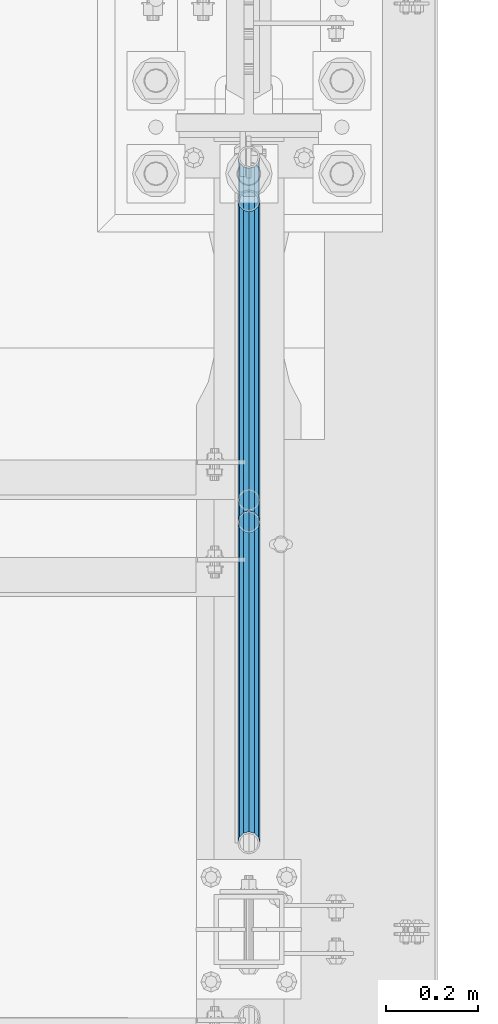
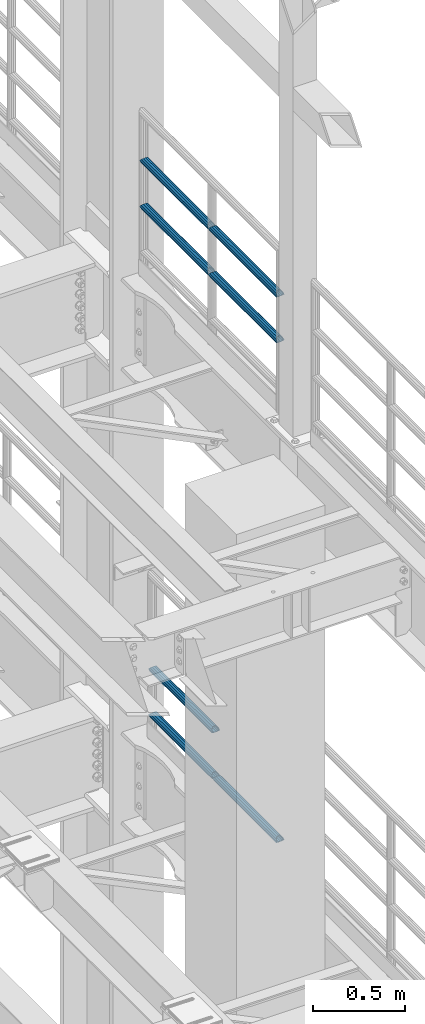
# One storey, part 1336 of 1876: 7 beams, 2 elements without a shape of their own.
"""IFC2X3 building model written with IfcOpenShell, lengths in millimetres."""

import ifcopenshell
import ifcopenshell.guid

model = None  # the IFC model being written
_history = None  # IfcOwnerHistory: only IFC2X3 demands one
_inside = {}  # id of a spatial element -> (the spatial element, [elements in it])
_under = {}  # id of a project, library or spatial element -> (it, [spatial elements below it])
_declared = {}  # id of a project -> (the project, [libraries it declares])
_typed = {}  # id of a type object -> (the type object, [elements of that type])
_made_of = {}  # id of a material, layer set ... -> (it, [elements and type objects made of it])


def new_model(schema):
    """Start an empty IFC model of exactly this schema.

    Asked for "IFC4X3", IfcOpenShell would pick the latest addendum, in which some entities
    have other attributes; the version numbers below select the first issue.
    IFC2X3 requires an IfcOwnerHistory on every rooted entity: one is made here for all.
    """
    global model, _history
    if schema == "IFC4X3":
        model = ifcopenshell.file(schema_version=(4, 3, 0, 0))
    else:
        model = ifcopenshell.file(schema=schema)
    _inside.clear()
    _under.clear()
    _declared.clear()
    _typed.clear()
    _made_of.clear()
    _history = None
    if model.schema == "IFC2X3":
        org = make("IfcOrganization", Name="unknown")
        user = make(
            "IfcPersonAndOrganization",
            ThePerson=make("IfcPerson", FamilyName="unknown"),
            TheOrganization=org,
        )
        app = make(
            "IfcApplication",
            ApplicationDeveloper=org,
            Version="unknown",
            ApplicationFullName="unknown",
            ApplicationIdentifier="unknown",
        )
        _history = make(
            "IfcOwnerHistory",
            OwningUser=user,
            OwningApplication=app,
            ChangeAction="ADDED",
            CreationDate=0,
        )
    return model


def make(cls, **values):
    """One entity of the class cls with the attributes given. An attribute that is None is left unset."""
    return model.create_entity(
        cls, **{name: value for name, value in values.items() if value is not None}
    )


def rooted(cls, **values):
    """An entity with a GlobalId (a new one), such as an element, a storey or a relation."""
    return make(cls, GlobalId=ifcopenshell.guid.new(), OwnerHistory=_history, **values)


def si_unit(unit_type, name, prefix=None):
    """IfcSIUnit, for example si_unit("LENGTHUNIT", "METRE", prefix="MILLI")."""
    return make("IfcSIUnit", UnitType=unit_type, Prefix=prefix, Name=name)


def assignment(units):
    """IfcUnitAssignment: the units of a project."""
    return None if units is None else make("IfcUnitAssignment", Units=units)


def point(xyz):
    """IfcCartesianPoint."""
    return None if xyz is None else make("IfcCartesianPoint", Coordinates=xyz)


def direction(xyz):
    """IfcDirection."""
    return None if xyz is None else make("IfcDirection", DirectionRatios=xyz)


def frame(location, z_axis=None, x_axis=None):
    """IfcAxis2Placement3D, a coordinate frame: its origin and axes. An axis left out is left unset."""
    return make(
        "IfcAxis2Placement3D",
        Location=point(location),
        Axis=direction(z_axis),
        RefDirection=direction(x_axis),
    )


def origin_with_axes():
    """The frame at (0, 0, 0) with the z axis (0, 0, 1) and the x axis (1, 0, 0) written out."""
    return frame((0.0, 0.0, 0.0), z_axis=(0.0, 0.0, 1.0), x_axis=(1.0, 0.0, 0.0))


def place(relative_to, where):
    """IfcLocalPlacement: puts the frame where relative to a parent placement (None: the world)."""
    return make(
        "IfcLocalPlacement", PlacementRelTo=relative_to, RelativePlacement=where
    )


def context(
    kind, dimensions, precision=None, world=None, true_north=None, identifier=None
):
    """IfcGeometricRepresentationContext, for example the 3D "Model" context."""
    return make(
        "IfcGeometricRepresentationContext",
        ContextIdentifier=identifier,
        ContextType=kind,
        CoordinateSpaceDimension=dimensions,
        Precision=precision,
        WorldCoordinateSystem=world,
        TrueNorth=true_north,
    )


def subcontext(parent, identifier, kind, view, scale=None):
    """IfcGeometricRepresentationSubContext, for example "Body" below "Model"."""
    return make(
        "IfcGeometricRepresentationSubContext",
        ContextIdentifier=identifier,
        ContextType=kind,
        ParentContext=parent,
        TargetScale=scale,
        TargetView=view,
    )


def project(units=None, contexts=None):
    """IfcProject with its units and contexts."""
    return rooted(
        "IfcProject",
        Name="project",
        RepresentationContexts=contexts,
        UnitsInContext=assignment(units),
    )


def spatial(cls, under=None, at=None, **own):
    """A site, building, storey or space (cls), placed at a placement, below another one or the project."""
    s = rooted(cls, ObjectPlacement=at, **own)
    if under is not None:
        _under.setdefault(under.id(), (under, []))[1].append(s)
    return s


def faces_of(points, faces, orient=None, outer=None):
    """IfcFace entities. A face is a list of loops; a loop is a list of indices into points, from 0.

    orient and outer hold one flag for each loop. By default every Orientation is true, the
    first loop of a face is its IfcFaceOuterBound and the others are IfcFaceBound.
    """
    made = []
    for i, loops in enumerate(faces):
        bounds = []
        for j, loop in enumerate(loops):
            is_outer = j == 0 if outer is None else outer[i][j]
            bounds.append(
                make(
                    "IfcFaceOuterBound" if is_outer else "IfcFaceBound",
                    Bound=make("IfcPolyLoop", Polygon=[points[k] for k in loop]),
                    Orientation=True if orient is None else orient[i][j],
                )
            )
        made.append(make("IfcFace", Bounds=bounds))
    return made


def faceted_brep(points, faces, orient=None, outer=None, voids=None):
    """IfcFacetedBrep: a solid bounded by flat faces; with voids (closed shells), ...WithVoids."""
    shared = [point(p) for p in points]
    hull = make("IfcClosedShell", CfsFaces=faces_of(shared, faces, orient, outer))
    if voids is None:
        return make("IfcFacetedBrep", Outer=hull)
    return make(
        "IfcFacetedBrepWithVoids",
        Outer=hull,
        Voids=[
            make(cls, CfsFaces=faces_of(shared, fs, o, b)) for cls, fs, o, b in voids
        ],
    )


def shape(context_of_items, identifier, shape_type, items):
    """IfcShapeRepresentation: the items that make up one representation, for example the "Body"."""
    return make(
        "IfcShapeRepresentation",
        ContextOfItems=context_of_items,
        RepresentationIdentifier=identifier,
        RepresentationType=shape_type,
        Items=items,
    )


def material(Name=None, Category=None):
    """IfcMaterial."""
    return make("IfcMaterial", Name=Name, Category=Category)


def made_of(thing, what):
    """Note that an element or type object is made of a material, layer set ...; save() writes the relation."""
    if what is not None:
        _made_of.setdefault(what.id(), (what, []))[1].append(thing)
    return thing


def type_object(cls, material=None, **own):
    """A type object (cls), such as IfcWallType, which elements share."""
    return made_of(rooted(cls, **own), material)


def element(
    cls,
    number,
    at=None,
    inside=None,
    cuts=None,
    type_object=None,
    material=None,
    context=None,
    identifier="Body",
    shape_type=None,
    held_by="IfcProductDefinitionShape",
    body=None,
    shapes=None,
    **own,
):
    """One element of the class cls, such as IfcWall. Its Tag is "e" and its number.

    at: its placement. inside: the storey or other place that contains it. cuts: it is an
    opening in that element (IfcRelVoidsElement). A single representation is given by context,
    identifier, shape_type and body (its items); several are given by shapes. held_by: the class
    of the entity that holds the representations. save() writes the other relations.
    """
    e = rooted(cls, Tag="e%d" % number, ObjectPlacement=at, **own)
    if body is not None:
        shapes = [shape(context, identifier, shape_type, body)]
    if shapes is not None:
        e.Representation = make(held_by, Representations=shapes)
    if inside is not None:
        _inside.setdefault(inside.id(), (inside, []))[1].append(e)
    if cuts is not None:
        rooted(
            "IfcRelVoidsElement", RelatingBuildingElement=cuts, RelatedOpeningElement=e
        )
    if type_object is not None:
        _typed.setdefault(type_object.id(), (type_object, []))[1].append(e)
    return made_of(e, material)


def aggregate(whole, parts):
    """IfcRelAggregates: a whole, such as a stair, and the parts it consists of."""
    return rooted("IfcRelAggregates", RelatingObject=whole, RelatedObjects=parts)


def save(model, path):
    """Write the relations noted so far, then the file.

    IfcRelAggregates (storeys below a building ...), IfcRelContainedInSpatialStructure (elements
    in a storey), IfcRelDefinesByType, IfcRelAssociatesMaterial and IfcRelDeclares: one each for
    every whole, place, type object, material and project.
    """
    for whole, parts in _under.values():
        aggregate(whole, parts)
    for where, things in _inside.values():
        rooted(
            "IfcRelContainedInSpatialStructure",
            RelatedElements=things,
            RelatingStructure=where,
        )
    for kind, things in _typed.values():
        rooted("IfcRelDefinesByType", RelatedObjects=things, RelatingType=kind)
    for what, things in _made_of.values():
        rooted("IfcRelAssociatesMaterial", RelatedObjects=things, RelatingMaterial=what)
    for by, libraries in _declared.values():
        rooted("IfcRelDeclares", RelatingContext=by, RelatedDefinitions=libraries)
    model.write(path)


model = new_model("IFC2X3")

# Units and contexts
model_context = context("Model", 3, precision=1e-05, world=origin_with_axes())
body_context = subcontext(model_context, "Body", "Model", "MODEL_VIEW")
ifc_project = project(units=[si_unit("LENGTHUNIT", "METRE", prefix="MILLI"), si_unit("AREAUNIT", "SQUARE_METRE"), si_unit("VOLUMEUNIT", "CUBIC_METRE"), si_unit("MASSUNIT", "GRAM", prefix="KILO"), si_unit("TIMEUNIT", "SECOND"), si_unit("PLANEANGLEUNIT", "RADIAN"), si_unit("SOLIDANGLEUNIT", "STERADIAN"), si_unit("THERMODYNAMICTEMPERATUREUNIT", "DEGREE_CELSIUS"), si_unit("LUMINOUSINTENSITYUNIT", "LUMEN")], contexts=[model_context])

# Site, building, storey
site_placement = place(None, origin_with_axes())
site = spatial("IfcSite", under=ifc_project, at=site_placement, CompositionType="ELEMENT")
building_placement = place(site_placement, origin_with_axes())
building = spatial("IfcBuilding", under=site, at=building_placement, Name="Undefined", CompositionType="ELEMENT")
storey_placement = place(building_placement, origin_with_axes())
storey = spatial("IfcBuildingStorey", under=building, at=storey_placement, Name="Undefined", CompositionType="ELEMENT", Elevation=0.0)

# Assembly, beams
assembly_1_placement = place(storey_placement, origin_with_axes())
assembly_1 = element("IfcElementAssembly", 1, at=assembly_1_placement, inside=storey, Name="RAIL", AssemblyPlace="NOTDEFINED", PredefinedType="RIGID_FRAME")
ifc_material = material()
beam_type = type_object("IfcBeamType", Name="PIPE1-1/2SCH40", PredefinedType="NOTDEFINED")
beam_1_placement = place(assembly_1_placement, frame((7620.0, 5777.23, 8620.125), z_axis=(0.0, 0.0, -1.0), x_axis=(0.0, 1.0, 0.0)))
beam_1 = element("IfcBeam", 2, at=beam_1_placement, type_object=beam_type, material=ifc_material, Name="RAIL", ObjectType="PIPE1-1/2SCH40", context=body_context, shape_type="Brep", body=[
    faceted_brep([(0.0, 24.1299999999992, 0.0), (12.0650000000064, 20.8971929933177, -12.0649999999987), (12.0650000000064, 20.8971929933177, 12.0649999999987), (12.0650000000064, -20.8971929933177, 12.0649999999987), (12.0650000000064, -20.8971929933177, -12.0649999999987), (0.0, -24.1299999999992, 0.0), (20.8971929933249, -12.0650000000005, 20.8971929933177), (20.8971929933249, -12.0650000000005, 15.8661214311796), (15.2545715621445, -17.7076214311801, 10.2235000000001), (12.5151929933249, -20.4470000000001, 0.0), (15.2545715621445, -17.7076214311801, -10.2235000000001), (20.8971929933249, -12.0650000000005, -15.8661214311796), (20.8971929933249, -12.0650000000005, -20.8971929933177), (24.1300000000063, 0.0, -20.4470000000001), (24.1300000000063, 0.0, -24.130000000001), (21.3906214311868, -10.2235000000001, -17.7076214311819), (21.3906214311868, 10.2235000000001, -17.7076214311819), (20.8971929933249, 12.0650000000005, -15.8661214311796), (20.8971929933249, 12.0650000000005, -20.8971929933177), (15.2545715621445, 17.7076214311801, -10.2235000000001), (12.5151929933249, 20.4470000000001, 0.0), (15.2545715621445, 17.7076214311801, 10.2235000000001), (20.8971929933249, 12.0650000000005, 15.8661214311796), (20.8971929933249, 12.0650000000005, 20.8971929933177), (21.3906214311868, 10.2235000000001, 17.7076214311819), (24.1300000000064, 0.0, 20.4470000000001), (24.1300000000064, 0.0, 24.130000000001), (21.3906214311868, -10.2235000000001, 17.7076214311819), (748.982500000002, 24.1300000000001, 0.0), (736.917500000002, 20.8971929933186, -12.0649999999987), (728.085307006683, 12.0649999999996, -20.8971929933177), (748.982500000002, -24.1300000000001, 0.0), (736.917500000002, -20.8971929933186, -12.0649999999987), (736.917500000002, -20.8971929933186, 12.0649999999987), (728.085307006683, -12.0649999999996, 20.8971929933177), (728.085307006683, -12.0649999999996, -20.8971929933177), (724.852500000002, 0.0, -24.130000000001), (727.591878568821, 10.2235000000001, -17.7076214311819), (724.852500000002, 0.0, -20.4470000000001), (728.085307006683, 12.0649999999996, -15.8661214311796), (728.085307006683, -12.0649999999996, -15.8661214311796), (727.591878568821, -10.2235000000001, -17.7076214311819), (733.727928437864, -17.7076214311801, -10.2235000000001), (736.467307006683, -20.4470000000001, 0.0), (733.727928437864, -17.7076214311801, 10.2235000000001), (728.085307006683, -12.0649999999996, 15.8661214311796), (727.591878568821, -10.2235000000001, 17.7076214311819), (724.852500000002, 0.0, 20.4470000000001), (724.852500000002, 0.0, 24.130000000001), (728.085307006683, 12.0649999999996, 20.8971929933177), (736.917500000002, 20.8971929933186, 12.0649999999987), (728.085307006683, 12.0649999999996, 15.8661214311796), (733.727928437864, 17.7076214311801, 10.2235000000001), (736.467307006683, 20.4470000000001, 0.0), (733.727928437864, 17.7076214311801, -10.2235000000001), (727.591878568821, 10.2235000000001, 17.7076214311819)], [[[0, 1, 2]], [[3, 4, 5]], [[6, 7, 8, 9, 10, 11, 12, 4, 3]], [[13, 14, 12, 11, 15]], [[16, 17, 18, 14, 13]], [[2, 1, 18, 17, 19, 20, 21, 22, 23]], [[23, 22, 24, 25, 26]], [[26, 25, 27, 7, 6]], [[1, 0, 28, 29]], [[18, 1, 29, 30]], [[31, 32, 33]], [[6, 3, 33, 34]], [[3, 5, 31, 33]], [[5, 4, 32, 31]], [[4, 12, 35, 32]], [[12, 14, 36, 35]], [[14, 18, 30, 36]], [[37, 38, 36, 30, 39]], [[40, 35, 36, 38, 41]], [[33, 32, 35, 40, 42, 43, 44, 45, 34]], [[34, 45, 46, 47, 48]], [[26, 6, 34, 48]], [[2, 23, 49, 50]], [[23, 26, 48, 49]], [[0, 2, 50, 28]], [[28, 50, 29]], [[49, 51, 52, 53, 54, 39, 30, 29, 50]], [[48, 47, 55, 51, 49]], [[25, 24, 55, 47]], [[55, 24, 22, 21, 52, 51]], [[21, 20, 53, 52]], [[20, 19, 54, 53]], [[19, 17, 16, 37, 39, 54]], [[16, 13, 38, 37]], [[13, 15, 41, 38]], [[41, 15, 11, 10, 42, 40]], [[10, 9, 43, 42]], [[9, 8, 44, 43]], [[8, 7, 27, 46, 45, 44]], [[27, 25, 47, 46]]]),
])
beam_2_placement = place(assembly_1_placement, frame((7620.0, 6526.2125, 8620.125), z_axis=(0.0, 0.0, -1.0), x_axis=(0.0, 1.0, 0.0)))
beam_2 = element("IfcBeam", 3, at=beam_2_placement, type_object=beam_type, material=ifc_material, Name="RAIL", ObjectType="PIPE1-1/2SCH40", context=body_context, shape_type="Brep", body=[
    faceted_brep([(0.0, 24.1299999999992, 0.0), (12.0650000000064, 20.8971929933177, -12.0649999999987), (12.0650000000064, 20.8971929933177, 12.0649999999987), (12.0650000000064, -20.8971929933177, 12.0649999999987), (12.0650000000064, -20.8971929933177, -12.0649999999987), (0.0, -24.1299999999992, 0.0), (20.8971929933249, -12.0650000000005, 20.8971929933177), (20.8971929933249, -12.0650000000005, 15.8661214311796), (15.2545715621445, -17.7076214311801, 10.2235000000001), (12.5151929933249, -20.4470000000001, 0.0), (15.2545715621445, -17.7076214311801, -10.2235000000001), (20.8971929933249, -12.0650000000005, -15.8661214311796), (20.8971929933249, -12.0650000000005, -20.8971929933177), (24.1300000000063, 0.0, -20.4470000000001), (24.1300000000063, 0.0, -24.130000000001), (21.3906214311868, -10.2235000000001, -17.7076214311819), (21.3906214311868, 10.2235000000001, -17.7076214311819), (20.8971929933249, 12.0650000000005, -15.8661214311796), (20.8971929933249, 12.0650000000005, -20.8971929933177), (15.2545715621445, 17.7076214311801, -10.2235000000001), (12.5151929933249, 20.4470000000001, 0.0), (15.2545715621445, 17.7076214311801, 10.2235000000001), (20.8971929933249, 12.0650000000005, 15.8661214311796), (20.8971929933249, 12.0650000000005, 20.8971929933177), (21.3906214311868, 10.2235000000001, 17.7076214311819), (24.1300000000064, 0.0, 20.4470000000001), (24.1300000000064, 0.0, 24.130000000001), (21.3906214311868, -10.2235000000001, 17.7076214311819), (748.982500000002, 24.1300000000001, 0.0), (736.917500000002, 20.8971929933186, -12.0649999999987), (728.085307006683, 12.0649999999996, -20.8971929933177), (748.982500000002, -24.1300000000001, 0.0), (736.917500000002, -20.8971929933186, -12.0649999999987), (736.917500000002, -20.8971929933186, 12.0649999999987), (728.085307006683, -12.0649999999996, 20.8971929933177), (728.085307006683, -12.0649999999996, -20.8971929933177), (724.852500000002, 0.0, -24.130000000001), (727.591878568821, 10.2235000000001, -17.7076214311819), (724.852500000002, 0.0, -20.4470000000001), (728.085307006683, 12.0649999999996, -15.8661214311796), (728.085307006683, -12.0649999999996, -15.8661214311796), (727.591878568821, -10.2235000000001, -17.7076214311819), (733.727928437864, -17.7076214311801, -10.2235000000001), (736.467307006683, -20.4470000000001, 0.0), (733.727928437864, -17.7076214311801, 10.2235000000001), (728.085307006683, -12.0649999999996, 15.8661214311796), (727.591878568821, -10.2235000000001, 17.7076214311819), (724.852500000002, 0.0, 20.4470000000001), (724.852500000002, 0.0, 24.130000000001), (728.085307006683, 12.0649999999996, 20.8971929933177), (736.917500000002, 20.8971929933186, 12.0649999999987), (728.085307006683, 12.0649999999996, 15.8661214311796), (733.727928437864, 17.7076214311801, 10.2235000000001), (736.467307006683, 20.4470000000001, 0.0), (733.727928437864, 17.7076214311801, -10.2235000000001), (727.591878568821, 10.2235000000001, 17.7076214311819)], [[[0, 1, 2]], [[3, 4, 5]], [[6, 7, 8, 9, 10, 11, 12, 4, 3]], [[13, 14, 12, 11, 15]], [[16, 17, 18, 14, 13]], [[2, 1, 18, 17, 19, 20, 21, 22, 23]], [[23, 22, 24, 25, 26]], [[26, 25, 27, 7, 6]], [[1, 0, 28, 29]], [[18, 1, 29, 30]], [[31, 32, 33]], [[6, 3, 33, 34]], [[3, 5, 31, 33]], [[5, 4, 32, 31]], [[4, 12, 35, 32]], [[12, 14, 36, 35]], [[14, 18, 30, 36]], [[37, 38, 36, 30, 39]], [[40, 35, 36, 38, 41]], [[33, 32, 35, 40, 42, 43, 44, 45, 34]], [[34, 45, 46, 47, 48]], [[26, 6, 34, 48]], [[2, 23, 49, 50]], [[23, 26, 48, 49]], [[0, 2, 50, 28]], [[28, 50, 29]], [[49, 51, 52, 53, 54, 39, 30, 29, 50]], [[48, 47, 55, 51, 49]], [[25, 24, 55, 47]], [[55, 24, 22, 21, 52, 51]], [[21, 20, 53, 52]], [[20, 19, 54, 53]], [[19, 17, 16, 37, 39, 54]], [[16, 13, 38, 37]], [[13, 15, 41, 38]], [[41, 15, 11, 10, 42, 40]], [[10, 9, 43, 42]], [[9, 8, 44, 43]], [[8, 7, 27, 46, 45, 44]], [[27, 25, 47, 46]]]),
])
beam_3_placement = place(assembly_1_placement, frame((7620.0, 5777.23, 8924.925), z_axis=(0.0, 0.0, -1.0), x_axis=(0.0, 1.0, 0.0)))
beam_3 = element("IfcBeam", 4, at=beam_3_placement, type_object=beam_type, material=ifc_material, Name="RAIL", ObjectType="PIPE1-1/2SCH40", context=body_context, shape_type="Brep", body=[
    faceted_brep([(0.0, 24.1299999999992, 0.0), (12.0650000000064, 20.8971929933177, -12.0649999999987), (12.0650000000064, 20.8971929933177, 12.0649999999987), (12.0650000000064, -20.8971929933177, 12.0649999999987), (12.0650000000064, -20.8971929933177, -12.0649999999987), (0.0, -24.1299999999992, 0.0), (20.8971929933249, -12.0650000000005, 20.8971929933177), (20.8971929933249, -12.0650000000005, 15.8661214311796), (15.2545715621445, -17.7076214311801, 10.2235000000001), (12.5151929933249, -20.4470000000001, 0.0), (15.2545715621445, -17.7076214311801, -10.2235000000001), (20.8971929933249, -12.0650000000005, -15.8661214311796), (20.8971929933249, -12.0650000000005, -20.8971929933177), (24.1300000000063, 0.0, -20.4470000000001), (24.1300000000063, 0.0, -24.130000000001), (21.3906214311868, -10.2235000000001, -17.7076214311819), (21.3906214311868, 10.2235000000001, -17.7076214311819), (20.8971929933249, 12.0650000000005, -15.8661214311796), (20.8971929933249, 12.0650000000005, -20.8971929933177), (15.2545715621445, 17.7076214311801, -10.2235000000001), (12.5151929933249, 20.4470000000001, 0.0), (15.2545715621445, 17.7076214311801, 10.2235000000001), (20.8971929933249, 12.0650000000005, 15.8661214311796), (20.8971929933249, 12.0650000000005, 20.8971929933177), (21.3906214311868, 10.2235000000001, 17.7076214311819), (24.1300000000064, 0.0, 20.4470000000001), (24.1300000000064, 0.0, 24.130000000001), (21.3906214311868, -10.2235000000001, 17.7076214311819), (748.982500000002, 24.1300000000001, 0.0), (736.917500000002, 20.8971929933186, -12.0649999999987), (728.085307006683, 12.0649999999996, -20.8971929933177), (748.982500000002, -24.1300000000001, 0.0), (736.917500000002, -20.8971929933186, -12.0649999999987), (736.917500000002, -20.8971929933186, 12.0649999999987), (728.085307006683, -12.0649999999996, 20.8971929933177), (728.085307006683, -12.0649999999996, -20.8971929933177), (724.852500000002, 0.0, -24.130000000001), (727.591878568821, 10.2235000000001, -17.7076214311819), (724.852500000002, 0.0, -20.4470000000001), (728.085307006683, 12.0649999999996, -15.8661214311796), (728.085307006683, -12.0649999999996, -15.8661214311796), (727.591878568821, -10.2235000000001, -17.7076214311819), (733.727928437864, -17.7076214311801, -10.2235000000001), (736.467307006683, -20.4470000000001, 0.0), (733.727928437864, -17.7076214311801, 10.2235000000001), (728.085307006683, -12.0649999999996, 15.8661214311796), (727.591878568821, -10.2235000000001, 17.7076214311819), (724.852500000002, 0.0, 20.4470000000001), (724.852500000002, 0.0, 24.130000000001), (728.085307006683, 12.0649999999996, 20.8971929933177), (736.917500000002, 20.8971929933186, 12.0649999999987), (728.085307006683, 12.0649999999996, 15.8661214311796), (733.727928437864, 17.7076214311801, 10.2235000000001), (736.467307006683, 20.4470000000001, 0.0), (733.727928437864, 17.7076214311801, -10.2235000000001), (727.591878568821, 10.2235000000001, 17.7076214311819)], [[[0, 1, 2]], [[3, 4, 5]], [[6, 7, 8, 9, 10, 11, 12, 4, 3]], [[13, 14, 12, 11, 15]], [[16, 17, 18, 14, 13]], [[2, 1, 18, 17, 19, 20, 21, 22, 23]], [[23, 22, 24, 25, 26]], [[26, 25, 27, 7, 6]], [[1, 0, 28, 29]], [[18, 1, 29, 30]], [[31, 32, 33]], [[6, 3, 33, 34]], [[3, 5, 31, 33]], [[5, 4, 32, 31]], [[4, 12, 35, 32]], [[12, 14, 36, 35]], [[14, 18, 30, 36]], [[37, 38, 36, 30, 39]], [[40, 35, 36, 38, 41]], [[33, 32, 35, 40, 42, 43, 44, 45, 34]], [[34, 45, 46, 47, 48]], [[26, 6, 34, 48]], [[2, 23, 49, 50]], [[23, 26, 48, 49]], [[0, 2, 50, 28]], [[28, 50, 29]], [[49, 51, 52, 53, 54, 39, 30, 29, 50]], [[48, 47, 55, 51, 49]], [[25, 24, 55, 47]], [[55, 24, 22, 21, 52, 51]], [[21, 20, 53, 52]], [[20, 19, 54, 53]], [[19, 17, 16, 37, 39, 54]], [[16, 13, 38, 37]], [[13, 15, 41, 38]], [[41, 15, 11, 10, 42, 40]], [[10, 9, 43, 42]], [[9, 8, 44, 43]], [[8, 7, 27, 46, 45, 44]], [[27, 25, 47, 46]]]),
])
beam_4_placement = place(assembly_1_placement, frame((7620.0, 6526.2125, 8924.925), z_axis=(0.0, 0.0, -1.0), x_axis=(0.0, 1.0, 0.0)))
beam_4 = element("IfcBeam", 5, at=beam_4_placement, type_object=beam_type, material=ifc_material, Name="RAIL", ObjectType="PIPE1-1/2SCH40", context=body_context, shape_type="Brep", body=[
    faceted_brep([(0.0, 24.1299999999992, 0.0), (12.0650000000064, 20.8971929933177, -12.0649999999987), (12.0650000000064, 20.8971929933177, 12.0649999999987), (12.0650000000064, -20.8971929933177, 12.0649999999987), (12.0650000000064, -20.8971929933177, -12.0649999999987), (0.0, -24.1299999999992, 0.0), (20.8971929933249, -12.0650000000005, 20.8971929933177), (20.8971929933249, -12.0650000000005, 15.8661214311796), (15.2545715621445, -17.7076214311801, 10.2235000000001), (12.5151929933249, -20.4470000000001, 0.0), (15.2545715621445, -17.7076214311801, -10.2235000000001), (20.8971929933249, -12.0650000000005, -15.8661214311796), (20.8971929933249, -12.0650000000005, -20.8971929933177), (24.1300000000063, 0.0, -20.4470000000001), (24.1300000000063, 0.0, -24.130000000001), (21.3906214311868, -10.2235000000001, -17.7076214311819), (21.3906214311868, 10.2235000000001, -17.7076214311819), (20.8971929933249, 12.0650000000005, -15.8661214311796), (20.8971929933249, 12.0650000000005, -20.8971929933177), (15.2545715621445, 17.7076214311801, -10.2235000000001), (12.5151929933249, 20.4470000000001, 0.0), (15.2545715621445, 17.7076214311801, 10.2235000000001), (20.8971929933249, 12.0650000000005, 15.8661214311796), (20.8971929933249, 12.0650000000005, 20.8971929933177), (21.3906214311868, 10.2235000000001, 17.7076214311819), (24.1300000000064, 0.0, 20.4470000000001), (24.1300000000064, 0.0, 24.130000000001), (21.3906214311868, -10.2235000000001, 17.7076214311819), (748.982500000002, 24.1300000000001, 0.0), (736.917500000002, 20.8971929933186, -12.0649999999987), (728.085307006683, 12.0649999999996, -20.8971929933177), (748.982500000002, -24.1300000000001, 0.0), (736.917500000002, -20.8971929933186, -12.0649999999987), (736.917500000002, -20.8971929933186, 12.0649999999987), (728.085307006683, -12.0649999999996, 20.8971929933177), (728.085307006683, -12.0649999999996, -20.8971929933177), (724.852500000002, 0.0, -24.130000000001), (727.591878568821, 10.2235000000001, -17.7076214311819), (724.852500000002, 0.0, -20.4470000000001), (728.085307006683, 12.0649999999996, -15.8661214311796), (728.085307006683, -12.0649999999996, -15.8661214311796), (727.591878568821, -10.2235000000001, -17.7076214311819), (733.727928437864, -17.7076214311801, -10.2235000000001), (736.467307006683, -20.4470000000001, 0.0), (733.727928437864, -17.7076214311801, 10.2235000000001), (728.085307006683, -12.0649999999996, 15.8661214311796), (727.591878568821, -10.2235000000001, 17.7076214311819), (724.852500000002, 0.0, 20.4470000000001), (724.852500000002, 0.0, 24.130000000001), (728.085307006683, 12.0649999999996, 20.8971929933177), (736.917500000002, 20.8971929933186, 12.0649999999987), (728.085307006683, 12.0649999999996, 15.8661214311796), (733.727928437864, 17.7076214311801, 10.2235000000001), (736.467307006683, 20.4470000000001, 0.0), (733.727928437864, 17.7076214311801, -10.2235000000001), (727.591878568821, 10.2235000000001, 17.7076214311819)], [[[0, 1, 2]], [[3, 4, 5]], [[6, 7, 8, 9, 10, 11, 12, 4, 3]], [[13, 14, 12, 11, 15]], [[16, 17, 18, 14, 13]], [[2, 1, 18, 17, 19, 20, 21, 22, 23]], [[23, 22, 24, 25, 26]], [[26, 25, 27, 7, 6]], [[1, 0, 28, 29]], [[18, 1, 29, 30]], [[31, 32, 33]], [[6, 3, 33, 34]], [[3, 5, 31, 33]], [[5, 4, 32, 31]], [[4, 12, 35, 32]], [[12, 14, 36, 35]], [[14, 18, 30, 36]], [[37, 38, 36, 30, 39]], [[40, 35, 36, 38, 41]], [[33, 32, 35, 40, 42, 43, 44, 45, 34]], [[34, 45, 46, 47, 48]], [[26, 6, 34, 48]], [[2, 23, 49, 50]], [[23, 26, 48, 49]], [[0, 2, 50, 28]], [[28, 50, 29]], [[49, 51, 52, 53, 54, 39, 30, 29, 50]], [[48, 47, 55, 51, 49]], [[25, 24, 55, 47]], [[55, 24, 22, 21, 52, 51]], [[21, 20, 53, 52]], [[20, 19, 54, 53]], [[19, 17, 16, 37, 39, 54]], [[16, 13, 38, 37]], [[13, 15, 41, 38]], [[41, 15, 11, 10, 42, 40]], [[10, 9, 43, 42]], [[9, 8, 44, 43]], [[8, 7, 27, 46, 45, 44]], [[27, 25, 47, 46]]]),
])
aggregate(assembly_1, [beam_1, beam_2, beam_3, beam_4])

assembly_2_placement = place(storey_placement, origin_with_axes())
assembly_2 = element("IfcElementAssembly", 6, at=assembly_2_placement, inside=storey, Name="RAIL", AssemblyPlace="NOTDEFINED", PredefinedType="RIGID_FRAME")
beam_5_placement = place(assembly_2_placement, frame((7620.00000000007, 6478.5698316807, 5292.73091229414), z_axis=(0.0, -8.42999999986204e-06, 0.999999999964468), x_axis=(0.0, 0.999999999964468, 8.43000000018809e-06)))
beam_5 = element("IfcBeam", 7, at=beam_5_placement, type_object=beam_type, material=ifc_material, Name="RAIL", ObjectType="PIPE1-1/2SCH40", context=body_context, shape_type="Brep", body=[
    faceted_brep([(680.442814874983, -12.0649999999996, 20.8971929933068), (680.44277246305, -12.0649999999277, 15.8661214312397), (679.949359549034, -10.2235000000001, 17.7076214311674), (677.210004073059, 2.72848410531878e-12, 20.4469999999883), (677.210035120749, 2.72848410531878e-12, 24.1299999999883), (679.949359548996, 10.2235000000001, 17.7076214311674), (680.44277246305, 12.0650000000714, 15.866121431096), (680.442814874983, 12.0649999999996, 20.8971929933068), (701.33983170571, 24.1300000000001, -1.45519152283669e-11), (689.27493341323, 20.8971929933186, 12.0649999999878), (689.27472999733, 20.8971929933186, -12.0650000000151), (686.085346327061, 17.7076214311801, 10.2234999999873), (688.824638711873, 20.4470000000001, -1.36424205265939e-11), (686.085173958852, 17.7076214311801, -10.2235000000137), (680.442504960242, 12.0650000000714, -15.8661214311223), (680.442462548309, 12.0649999999996, -20.8971929933323), (679.949060998498, 10.2235000000001, -17.7076214311946), (677.20965933664, 0.0, -20.4470000000147), (677.20962828895, 0.0, -24.1300000000147), (680.442504960242, -12.0649999999277, -15.866121431266), (680.442462548309, -12.0649999999996, -20.8971929933323), (679.949060998536, -10.2235000000001, -17.7076214311946), (701.33983170571, -24.1299999999283, -1.45519152283669e-11), (689.27472999733, -20.8971929933186, -12.0650000000151), (689.27493341323, -20.8971929933186, 12.0649999999878), (686.085173958994, -17.7076214311801, -10.2235000000137), (688.824638712016, -20.4470000000001, -1.36424205265939e-11), (686.085346327204, -17.7076214311801, 10.2234999999873), (12.0648982924813, -20.8971929933186, -12.0650000000005), (20.8970168307269, -12.0649999999996, -20.8971929933195), (0.0, 24.1299999999992, 0.0), (12.0648982924813, 20.8971929933186, -12.0650000000005), (12.065101708381, 20.8971929933186, 12.0650000000005), (20.897369157401, 12.0649999999996, 20.8971929933205), (24.1302034167611, 7.18500814400613e-11, 24.1300000000019), (20.8970168307269, 12.0649999999996, -20.8971929933195), (24.1297965849608, 0.0, -24.130000000001), (24.1298276326506, 0.0, -20.447000000001), (20.8970592426604, -12.0649999999277, -15.8661214312533), (21.390472156676, -10.2235000000001, -17.7076214311819), (21.3904721567151, 10.2235000000001, -17.7076214311819), (20.8970592426604, 12.0650000000714, -15.8661214311096), (15.2544853786503, 17.7076214311801, -10.2235000000001), (12.5151929933249, 20.4470000000001, 0.0), (15.2546577468602, 17.7076214311801, 10.223500000001), (20.8973267454676, 12.0650000000714, 15.8661214311096), (21.3907707072121, 10.2235000000001, 17.7076214311819), (24.1301723690713, 7.18500814400613e-11, 20.447000000001), (21.390770707173, -10.2235000000001, 17.7076214311819), (20.8973267454676, -12.0649999999277, 15.8661214312533), (20.897369157401, -12.0649999999996, 20.8971929933205), (12.065101708381, -20.8971929933186, 12.0650000000005), (0.0, -24.1299999999992, 0.0), (15.2546577467156, -17.7076214311801, 10.223500000001), (12.5151929933249, -20.4470000000001, 0.0), (15.2544853785057, -17.7076214311801, -10.2235000000001)], [[[0, 1, 2, 3, 4]], [[4, 3, 5, 6, 7]], [[8, 9, 10]], [[7, 6, 11, 12, 13, 14, 15, 10, 9]], [[16, 17, 18, 15, 14]], [[19, 20, 18, 17, 21]], [[22, 23, 24]], [[24, 23, 20, 19, 25, 26, 27, 1, 0]], [[28, 29, 20, 23]], [[30, 31, 32]], [[33, 34, 4, 7]], [[32, 33, 7, 9]], [[30, 32, 9, 8]], [[31, 30, 8, 10]], [[35, 31, 10, 15]], [[36, 35, 15, 18]], [[29, 36, 18, 20]], [[37, 36, 29, 38, 39]], [[40, 41, 35, 36, 37]], [[32, 31, 35, 41, 42, 43, 44, 45, 33]], [[33, 45, 46, 47, 34]], [[34, 47, 48, 49, 50]], [[34, 50, 0, 4]], [[50, 51, 24, 0]], [[51, 52, 22, 24]], [[52, 28, 23, 22]], [[51, 28, 52]], [[50, 49, 53, 54, 55, 38, 29, 28, 51]], [[55, 54, 26, 25]], [[21, 39, 38, 55, 25, 19]], [[37, 39, 21, 17]], [[40, 37, 17, 16]], [[42, 41, 40, 16, 14, 13]], [[43, 42, 13, 12]], [[44, 43, 12, 11]], [[5, 46, 45, 44, 11, 6]], [[47, 46, 5, 3]], [[48, 47, 3, 2]], [[53, 49, 48, 2, 1, 27]], [[54, 53, 27, 26]]]),
])
beam_6_placement = place(assembly_2_placement, frame((7620.00000000017, 5777.23, 5292.72499999952), z_axis=(0.0, -8.42999999986204e-06, 0.999999999964468), x_axis=(0.0, 0.999999999964468, 8.43000000018809e-06)))
beam_6 = element("IfcBeam", 8, at=beam_6_placement, type_object=beam_type, material=ifc_material, Name="RAIL", ObjectType="PIPE1-1/2SCH40", context=body_context, shape_type="Brep", body=[
    faceted_brep([(680.442814874983, -12.0649999999996, 20.8971929933068), (680.44277246305, -12.0649999999277, 15.8661214312397), (679.949359549034, -10.2235000000001, 17.7076214311674), (677.210004073059, 2.72848410531878e-12, 20.4469999999883), (677.210035120749, 2.72848410531878e-12, 24.1299999999883), (679.949359548996, 10.2235000000001, 17.7076214311674), (680.44277246305, 12.0650000000714, 15.866121431096), (680.442814874983, 12.0649999999996, 20.8971929933068), (701.33983170571, 24.1300000000001, -1.45519152283669e-11), (689.27493341323, 20.8971929933186, 12.0649999999878), (689.27472999733, 20.8971929933186, -12.0650000000151), (686.085346327061, 17.7076214311801, 10.2234999999873), (688.824638711873, 20.4470000000001, -1.36424205265939e-11), (686.085173958852, 17.7076214311801, -10.2235000000137), (680.442504960242, 12.0650000000714, -15.8661214311223), (680.442462548309, 12.0649999999996, -20.8971929933323), (679.949060998498, 10.2235000000001, -17.7076214311946), (677.20965933664, 0.0, -20.4470000000147), (677.20962828895, 0.0, -24.1300000000147), (680.442504960242, -12.0649999999277, -15.866121431266), (680.442462548309, -12.0649999999996, -20.8971929933323), (679.949060998536, -10.2235000000001, -17.7076214311946), (701.33983170571, -24.1299999999283, -1.45519152283669e-11), (689.27472999733, -20.8971929933186, -12.0650000000151), (689.27493341323, -20.8971929933186, 12.0649999999878), (686.085173958994, -17.7076214311801, -10.2235000000137), (688.824638712016, -20.4470000000001, -1.36424205265939e-11), (686.085346327204, -17.7076214311801, 10.2234999999873), (12.0648982924813, -20.8971929933186, -12.0650000000005), (20.8970168307269, -12.0649999999996, -20.8971929933195), (0.0, 24.1299999999992, 0.0), (12.0648982924813, 20.8971929933186, -12.0650000000005), (12.065101708381, 20.8971929933186, 12.0650000000005), (20.897369157401, 12.0649999999996, 20.8971929933205), (24.1302034167611, 7.18500814400613e-11, 24.1300000000019), (20.8970168307269, 12.0649999999996, -20.8971929933195), (24.1297965849608, 0.0, -24.130000000001), (24.1298276326506, 0.0, -20.447000000001), (20.8970592426604, -12.0649999999277, -15.8661214312533), (21.390472156676, -10.2235000000001, -17.7076214311819), (21.3904721567151, 10.2235000000001, -17.7076214311819), (20.8970592426604, 12.0650000000714, -15.8661214311096), (15.2544853786503, 17.7076214311801, -10.2235000000001), (12.5151929933249, 20.4470000000001, 0.0), (15.2546577468602, 17.7076214311801, 10.223500000001), (20.8973267454676, 12.0650000000714, 15.8661214311096), (21.3907707072121, 10.2235000000001, 17.7076214311819), (24.1301723690713, 7.18500814400613e-11, 20.447000000001), (21.390770707173, -10.2235000000001, 17.7076214311819), (20.8973267454676, -12.0649999999277, 15.8661214312533), (20.897369157401, -12.0649999999996, 20.8971929933205), (12.065101708381, -20.8971929933186, 12.0650000000005), (0.0, -24.1299999999992, 0.0), (15.2546577467156, -17.7076214311801, 10.223500000001), (12.5151929933249, -20.4470000000001, 0.0), (15.2544853785057, -17.7076214311801, -10.2235000000001)], [[[0, 1, 2, 3, 4]], [[4, 3, 5, 6, 7]], [[8, 9, 10]], [[7, 6, 11, 12, 13, 14, 15, 10, 9]], [[16, 17, 18, 15, 14]], [[19, 20, 18, 17, 21]], [[22, 23, 24]], [[24, 23, 20, 19, 25, 26, 27, 1, 0]], [[28, 29, 20, 23]], [[30, 31, 32]], [[33, 34, 4, 7]], [[32, 33, 7, 9]], [[30, 32, 9, 8]], [[31, 30, 8, 10]], [[35, 31, 10, 15]], [[36, 35, 15, 18]], [[29, 36, 18, 20]], [[37, 36, 29, 38, 39]], [[40, 41, 35, 36, 37]], [[32, 31, 35, 41, 42, 43, 44, 45, 33]], [[33, 45, 46, 47, 34]], [[34, 47, 48, 49, 50]], [[34, 50, 0, 4]], [[50, 51, 24, 0]], [[51, 52, 22, 24]], [[52, 28, 23, 22]], [[51, 28, 52]], [[50, 49, 53, 54, 55, 38, 29, 28, 51]], [[55, 54, 26, 25]], [[21, 39, 38, 55, 25, 19]], [[37, 39, 21, 17]], [[40, 37, 17, 16]], [[42, 41, 40, 16, 14, 13]], [[43, 42, 13, 12]], [[44, 43, 12, 11]], [[5, 46, 45, 44, 11, 6]], [[47, 46, 5, 3]], [[48, 47, 3, 2]], [[53, 49, 48, 2, 1, 27]], [[54, 53, 27, 26]]]),
])
beam_7_placement = place(assembly_2_placement, frame((7620.00000000031, 7179.9096633614, 5597.53682459919), z_axis=(0.0, 7.91400000045761e-06, -0.999999999968684), x_axis=(0.0, -0.999999999968684, -7.91400000071008e-06)))
beam_7 = element("IfcBeam", 9, at=beam_7_placement, type_object=beam_type, material=ifc_material, Name="RAIL", ObjectType="PIPE1-1/2SCH40", context=body_context, shape_type="Brep", body=[
    faceted_brep([(0.0, 24.1299999999992, 0.0), (12.0648982924813, 20.8971929933186, -12.0650000000005), (12.065101708381, 20.8971929933186, 12.0650000000005), (12.065101708381, -20.8971929933186, 12.0650000000005), (12.0648982924813, -20.8971929933186, -12.0650000000005), (0.0, -24.1299999999992, 0.0), (20.897369157401, -12.0649999999996, 20.8971929933205), (20.8973267454676, -12.0649999999277, 15.8661214312533), (15.2546577467156, -17.7076214311801, 10.223500000001), (12.5151929933249, -20.4470000000001, 0.0), (15.2544853785057, -17.7076214311801, -10.2235000000001), (20.8970592426604, -12.0649999999277, -15.8661214312533), (20.8970168307269, -12.0649999999996, -20.8971929933195), (24.1298276326506, 0.0, -20.447000000001), (24.1297965849608, 0.0, -24.130000000001), (21.390472156676, -10.2235000000001, -17.7076214311819), (21.3904721567151, 10.2235000000001, -17.7076214311819), (20.8970592426604, 12.0650000000714, -15.8661214311096), (20.8970168307269, 12.0649999999996, -20.8971929933195), (15.2544853786503, 17.7076214311801, -10.2235000000001), (12.5151929933249, 20.4470000000001, 0.0), (15.2546577468602, 17.7076214311801, 10.223500000001), (20.8973267454676, 12.0650000000714, 15.8661214311096), (20.897369157401, 12.0649999999996, 20.8971929933205), (21.3907707072121, 10.2235000000001, 17.7076214311819), (24.1301723690713, 7.18500814400613e-11, 20.447000000001), (24.1302034167611, 7.18500814400613e-11, 24.1300000000019), (21.390770707173, -10.2235000000001, 17.7076214311819), (701.33983170571, 24.1300000000001, -1.45519152283669e-11), (689.27472999733, 20.8971929933186, -12.0650000000151), (680.442462548309, 12.0649999999996, -20.8971929933323), (701.33983170571, -24.1299999999283, -1.45519152283669e-11), (689.27472999733, -20.8971929933186, -12.0650000000151), (689.27493341323, -20.8971929933186, 12.0649999999878), (680.442814874983, -12.0649999999996, 20.8971929933068), (680.442462548309, -12.0649999999996, -20.8971929933323), (677.20962828895, 0.0, -24.1300000000147), (679.949060998498, 10.2235000000001, -17.7076214311946), (677.20965933664, 0.0, -20.4470000000147), (680.442504960242, 12.0650000000714, -15.8661214311223), (680.442504960242, -12.0649999999277, -15.866121431266), (679.949060998536, -10.2235000000001, -17.7076214311946), (686.085173958994, -17.7076214311801, -10.2235000000137), (688.824638712016, -20.4470000000001, -1.36424205265939e-11), (686.085346327204, -17.7076214311801, 10.2234999999873), (680.44277246305, -12.0649999999277, 15.8661214312397), (679.949359549034, -10.2235000000001, 17.7076214311674), (677.210004073059, 2.72848410531878e-12, 20.4469999999883), (677.210035120749, 2.72848410531878e-12, 24.1299999999883), (680.442814874983, 12.0649999999996, 20.8971929933068), (689.27493341323, 20.8971929933186, 12.0649999999878), (680.44277246305, 12.0650000000714, 15.866121431096), (686.085346327061, 17.7076214311801, 10.2234999999873), (688.824638711873, 20.4470000000001, -1.36424205265939e-11), (686.085173958852, 17.7076214311801, -10.2235000000137), (679.949359548996, 10.2235000000001, 17.7076214311674)], [[[0, 1, 2]], [[3, 4, 5]], [[6, 7, 8, 9, 10, 11, 12, 4, 3]], [[13, 14, 12, 11, 15]], [[16, 17, 18, 14, 13]], [[2, 1, 18, 17, 19, 20, 21, 22, 23]], [[23, 22, 24, 25, 26]], [[26, 25, 27, 7, 6]], [[1, 0, 28, 29]], [[18, 1, 29, 30]], [[31, 32, 33]], [[6, 3, 33, 34]], [[3, 5, 31, 33]], [[5, 4, 32, 31]], [[4, 12, 35, 32]], [[12, 14, 36, 35]], [[14, 18, 30, 36]], [[37, 38, 36, 30, 39]], [[40, 35, 36, 38, 41]], [[33, 32, 35, 40, 42, 43, 44, 45, 34]], [[34, 45, 46, 47, 48]], [[26, 6, 34, 48]], [[2, 23, 49, 50]], [[23, 26, 48, 49]], [[0, 2, 50, 28]], [[28, 50, 29]], [[49, 51, 52, 53, 54, 39, 30, 29, 50]], [[48, 47, 55, 51, 49]], [[25, 24, 55, 47]], [[55, 24, 22, 21, 52, 51]], [[21, 20, 53, 52]], [[20, 19, 54, 53]], [[19, 17, 16, 37, 39, 54]], [[16, 13, 38, 37]], [[13, 15, 41, 38]], [[41, 15, 11, 10, 42, 40]], [[10, 9, 43, 42]], [[9, 8, 44, 43]], [[8, 7, 27, 46, 45, 44]], [[27, 25, 47, 46]]]),
])
aggregate(assembly_2, [beam_5, beam_6, beam_7])

save(model, "model.ifc")
